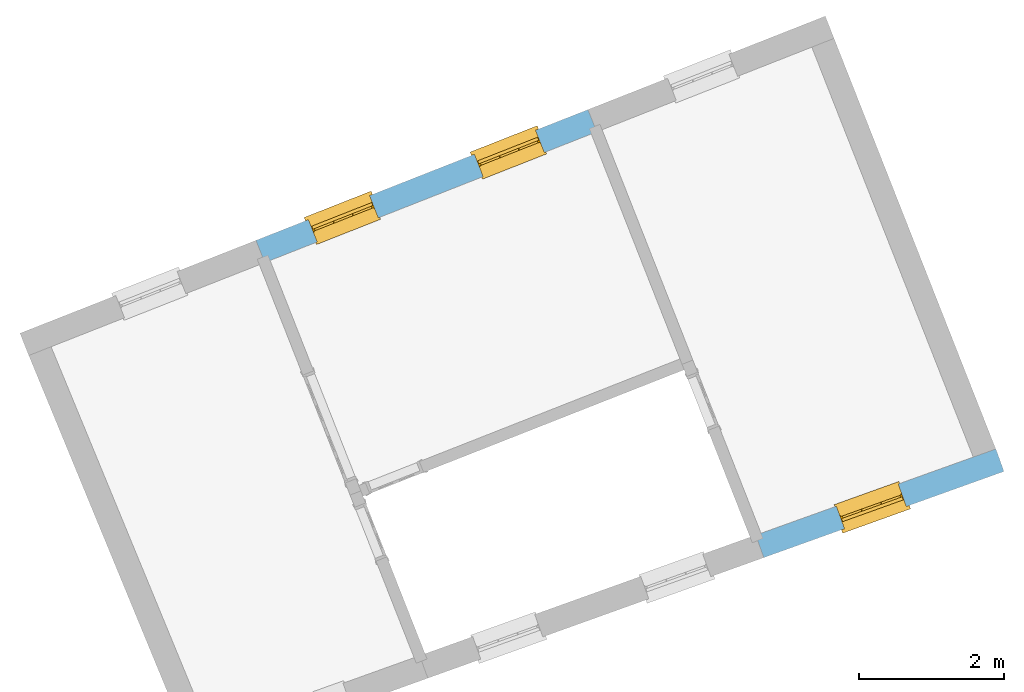
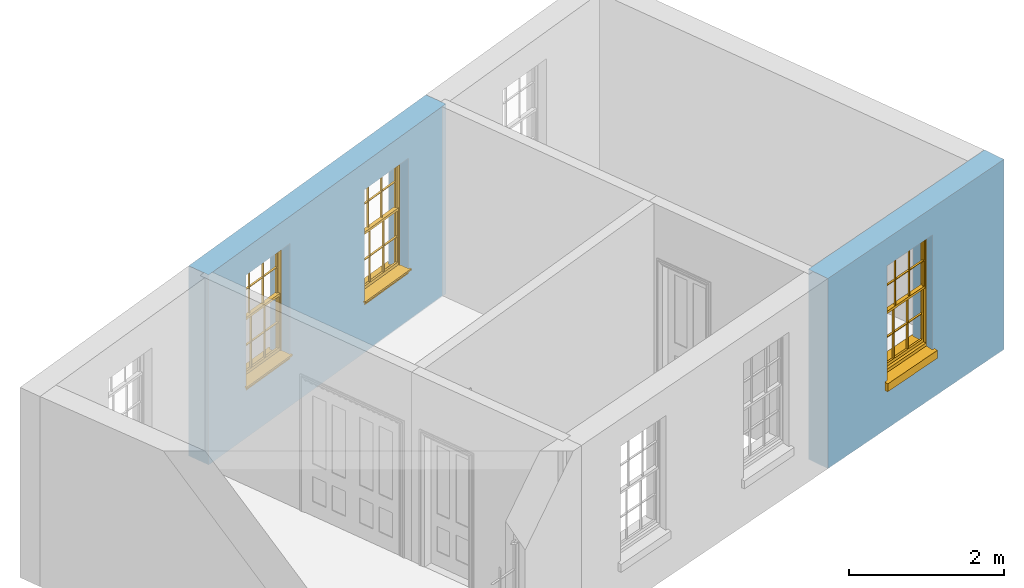
# One storey, part 5 of 6: 3 windows, 3 openings, plus 2 elements that do not belong to this part.
"""IFC2X3 building model written with IfcOpenShell, lengths in metres."""

from ifc_helpers import new_model, si_unit, frame, origin, place, context, subcontext, project, spatial, polyline, outline, extrude, faceted_brep, material, layer, layer_set, layer_usage, element, fill, save


model = new_model("IFC2X3")

# Units and contexts
model_context = context("Model", 3, world=origin())
body_context = subcontext(model_context, "Body", "Model", "MODEL_VIEW")
ifc_project = project(units=[si_unit("PLANEANGLEUNIT", "RADIAN"), si_unit("MASSUNIT", "GRAM", prefix="KILO"), si_unit("FORCEUNIT", "NEWTON", prefix="KILO"), si_unit("LENGTHUNIT", "METRE")], contexts=[model_context])

# Site, building, storey
site_placement = place(None, origin())
site = spatial("IfcSite", under=ifc_project, at=site_placement, CompositionType="ELEMENT")
building_placement = place(None, origin())
building = spatial("IfcBuilding", under=site, at=building_placement, Name="Building plot-4", CompositionType="ELEMENT")
storey_placement = place(None, frame((0.0, 0.0, 6.45)))
storey = spatial("IfcBuildingStorey", under=building, at=storey_placement, Name="Floor 1", CompositionType="ELEMENT", Elevation=6.45)

# Wall, openings, windows
ifc_material = material(Name="Masonry")
ifc_layer = layer(ifc_material, 0.33, ventilated=False)
ifc_layer_set = layer_set([ifc_layer], Name="My Wall")
ifc_layer_usage = layer_usage(ifc_layer_set, "AXIS2", "NEGATIVE", 0.08)
wall_1_placement = place(storey_placement, origin())
wall_1 = element("IfcWallStandardCase", 1, at=wall_1_placement, inside=storey, material=ifc_layer_usage, Name="exterior", context=body_context, shape_type="SweptSolid", body=[
    extrude(outline(polyline([(52.0366920680449, 53.7732303747513), (51.9157706887258, 54.0802776349957), (47.3314871355126, 52.2748946786277), (47.4524085148317, 51.9678474183833), (52.0366920680449, 53.7732303747513)])), origin(), (0.0, 0.0, 1.0), 3.0),
])
opening_1_placement = place(storey_placement, frame((0.0, 0.0, 0.75)))
opening_1 = element("IfcOpeningElement", 2, at=opening_1_placement, cuts=wall_1, Name="Opening", ObjectType="Opening", context=body_context, shape_type="SweptSolid", body=[
    extrude(outline(polyline([(51.1930528410624, 53.7956568279952), (50.3463467597826, 53.4622069638121), (50.4672681391017, 53.1551597035678), (51.3139742203816, 53.4886095677509), (51.1930528410624, 53.7956568279952)])), origin(), (0.0, 0.0, 1.0), 1.82),
])
opening_2_placement = place(storey_placement, frame((0.0, 0.0, 0.75)))
opening_2 = element("IfcOpeningElement", 3, at=opening_2_placement, cuts=wall_1, Name="Opening", ObjectType="Opening", context=body_context, shape_type="SweptSolid", body=[
    extrude(outline(polyline([(48.9009110644558, 52.8929653498112), (48.054204983176, 52.5595154856281), (48.1751263624951, 52.2524682253838), (49.021832443775, 52.5859180895669), (48.9009110644558, 52.8929653498112)])), origin(), (0.0, 0.0, 1.0), 1.82),
])
window_1_placement = place(storey_placement, frame((51.2846599466072, 53.563045267204, 0.75), z_axis=(0.0, 0.0, 1.0), x_axis=(-0.846706081279848, -0.333449864183102, 0.0)))
window_1 = element("IfcWindow", 4, at=window_1_placement, inside=storey, Name="living outside window", OverallHeight=1.82, OverallWidth=0.91, context=body_context, shape_type="Brep", held_by="IfcProductRepresentation", body=[
    faceted_brep([(0.033125, -0.105, 0.975209), (0.01, -0.105, 0.975209), (0.033125, -0.105, 1.376042), (0.876875, -0.105, 0.975209), (0.876875, -0.105, 1.376042), (0.9, -0.105, 0.975209), (0.876875, -0.105, 1.386042), (0.876875, -0.105, 1.786875), (0.9, -0.105, 1.81), (0.033125, -0.105, 1.786875), (0.033125, -0.105, 1.386042), (0.01, -0.105, 1.81), (0.876875, -0.135, 1.376042), (0.876875, -0.135, 0.975209), (0.9, -0.135, 0.937083), (0.033125, -0.135, 1.786875), (0.01, -0.135, 1.81), (0.033125, -0.135, 1.386042), (0.01, -0.135, 0.937083), (0.033125, -0.135, 0.975209), (0.033125, -0.135, 1.376042), (0.876875, -0.135, 1.786875), (0.876875, -0.135, 1.386042), (0.9, -0.135, 1.81), (0.033125, -0.105, 0.937083), (0.01, -0.105, 0.937083), (0.033125, -0.105, 0.53625), (0.876875, -0.105, 0.937083), (0.876875, -0.105, 0.53625), (0.9, -0.105, 0.937083), (0.876875, -0.105, 0.52625), (0.876875, -0.105, 0.125417), (0.9, -0.105, 0.077167), (0.033125, -0.105, 0.125417), (0.033125, -0.105, 0.52625), (0.01, -0.105, 0.077167), (-0.0425, -0.25, 0.01), (-0.0425, -0.3, 0.001667), (0.0, -0.25, 0.01), (0.9525, -0.25, 0.01), (0.91, -0.25, 0.01), (0.9525, -0.3, 0.001667), (-0.02, 0.08, 0.077167), (0.0, 0.08, 0.077167), (-0.02, 0.11, 0.077167), (0.0, -0.06, 0.077167), (0.01, -0.06, 0.077167), (0.91, -0.06, 0.077167), (0.91, 0.08, 0.077167), (0.9, -0.06, 0.077167), (0.93, 0.08, 0.077167), (0.93, 0.11, 0.077167), (0.01, -0.075, 0.975209), (0.9, -0.075, 0.975209), (0.876875, -0.075, 0.125417), (0.876875, -0.075, 0.52625), (0.9, -0.075, 0.077167), (0.876875, -0.075, 0.53625), (0.876875, -0.075, 0.937083), (0.033125, -0.075, 0.125417), (0.01, -0.075, 0.077167), (0.033125, -0.075, 0.52625), (0.033125, -0.075, 0.937083), (0.033125, -0.075, 0.53625), (-0.02, 0.08, 0.052167), (-0.02, 0.11, 0.052167), (0.93, 0.11, 0.052167), (0.93, 0.08, 0.052167), (0.91, 0.08, 0.052167), (0.0, 0.08, 0.052167), (0.91, -0.15, 0.026667), (0.0, -0.15, 0.026667), (-0.0425, -0.3, -0.123333), (0.9525, -0.3, -0.123333), (-0.0425, -0.25, -0.123333), (0.9525, -0.25, -0.123333), (0.01, -0.06, 1.81), (0.9, -0.06, 1.81), (0.0, -0.06, 1.82), (0.91, -0.06, 1.82), (0.01, -0.15, 0.077167), (0.9, -0.15, 0.077167), (0.592292, -0.105, 0.125417), (0.592292, -0.075, 0.125417), (0.317708, -0.075, 0.125417), (0.317708, -0.105, 0.125417), (0.592292, -0.105, 0.53625), (0.317708, -0.105, 0.53625), (0.317708, -0.105, 0.52625), (0.592292, -0.105, 0.52625), (0.592292, -0.075, 0.53625), (0.317708, -0.075, 0.53625), (0.592292, -0.135, 1.386042), (0.592292, -0.105, 1.386042), (0.317708, -0.105, 1.386042), (0.317708, -0.135, 1.386042), (0.317708, -0.135, 1.376042), (0.592292, -0.135, 1.376042), (0.317708, -0.105, 1.376042), (0.592292, -0.105, 1.376042), (0.602292, -0.135, 1.376042), (0.592292, -0.135, 0.975209), (0.602292, -0.135, 0.975209), (0.602292, -0.105, 0.975209), (0.592292, -0.105, 0.975209), (0.602292, -0.105, 1.376042), (0.602292, -0.075, 0.53625), (0.602292, -0.105, 0.53625), (0.317708, -0.075, 0.52625), (0.307708, -0.075, 0.125417), (0.307708, -0.075, 0.52625), (0.602292, -0.075, 0.52625), (0.602292, -0.075, 0.125417), (0.592292, -0.075, 0.52625), (0.307708, -0.075, 0.53625), (0.317708, -0.075, 0.937083), (0.307708, -0.075, 0.937083), (0.602292, -0.075, 0.937083), (0.592292, -0.075, 0.937083), (0.307708, -0.105, 0.52625), (0.307708, -0.105, 0.125417), (0.307708, -0.105, 0.53625), (0.307708, -0.105, 0.937083), (0.592292, -0.105, 0.937083), (0.317708, -0.105, 0.937083), (0.602292, -0.105, 0.937083), (0.602292, -0.105, 0.52625), (0.602292, -0.105, 0.125417), (0.307708, -0.135, 1.386042), (0.307708, -0.135, 1.376042), (0.307708, -0.135, 0.975209), (0.317708, -0.135, 0.975209), (0.317708, -0.135, 1.786875), (0.307708, -0.135, 1.786875), (0.602292, -0.135, 1.786875), (0.592292, -0.135, 1.786875), (0.602292, -0.135, 1.386042), (0.602292, -0.105, 1.386042), (0.307708, -0.105, 1.386042), (0.307708, -0.105, 1.786875), (0.317708, -0.105, 1.786875), (0.592292, -0.105, 1.786875), (0.602292, -0.105, 1.786875), (0.307708, -0.105, 1.376042), (0.317708, -0.105, 0.975209), (0.307708, -0.105, 0.975209), (0.91, -0.15, 1.82), (0.9, -0.15, 1.81), (0.01, -0.15, 1.81), (0.0, -0.15, 1.82), (0.91, -0.25, 0.0), (0.0, -0.25, 0.0), (0.91, 0.08, 0.0), (0.0, 0.08, 0.0)], [[[0, 1, 2]], [[3, 4, 5]], [[6, 7, 8]], [[9, 10, 11]], [[12, 13, 14]], [[15, 16, 17]], [[18, 19, 20]], [[21, 22, 23]], [[24, 25, 26]], [[27, 28, 29]], [[30, 31, 32]], [[33, 34, 35]], [[14, 27, 29]], [[25, 24, 18]], [[36, 37, 38]], [[39, 40, 41]], [[42, 43, 44]], [[45, 46, 43]], [[47, 48, 49]], [[50, 51, 48]], [[1, 0, 52]], [[5, 53, 3]], [[54, 55, 56]], [[57, 58, 53]], [[59, 60, 61]], [[62, 63, 52]], [[48, 43, 46, 49]], [[51, 44, 43, 48]], [[64, 42, 44, 65]], [[65, 44, 51, 66]], [[66, 51, 50, 67]], [[65, 66, 68, 69]], [[60, 56, 49, 46]], [[70, 71, 38, 40]], [[37, 41, 40, 38]], [[37, 72, 73, 41]], [[74, 75, 73, 72]], [[8, 11, 76, 77]], [[76, 78, 79, 77]], [[32, 35, 80, 81]], [[81, 80, 71, 70]], [[82, 83, 84, 85]], [[86, 87, 88, 89]], [[86, 90, 91, 87]], [[92, 93, 94, 95]], [[92, 95, 96, 97]], [[96, 98, 99, 97]], [[100, 97, 101, 102]], [[103, 104, 99, 105]], [[97, 99, 104, 101]], [[102, 103, 105, 100]], [[28, 57, 106, 107]], [[108, 84, 109, 110]], [[111, 112, 83, 113]], [[114, 110, 61, 63]], [[90, 113, 108, 91]], [[115, 91, 114, 116]], [[117, 106, 90, 118]], [[111, 106, 57, 55]], [[119, 110, 109, 120]], [[34, 61, 110, 119]], [[89, 113, 83, 82]], [[88, 108, 113, 89]], [[85, 84, 108, 88]], [[121, 114, 63, 26]], [[122, 116, 114, 121]], [[123, 118, 90, 86]], [[87, 91, 115, 124]], [[107, 106, 117, 125]], [[126, 111, 55, 30]], [[127, 112, 111, 126]], [[126, 30, 28, 107]], [[88, 119, 120, 85]], [[126, 89, 82, 127]], [[125, 123, 86, 107]], [[121, 26, 34, 119]], [[124, 122, 121, 87]], [[128, 17, 20, 129]], [[96, 129, 130, 131]], [[132, 133, 128, 95]], [[134, 135, 92, 136]], [[100, 12, 22, 136]], [[137, 6, 4, 105]], [[94, 138, 139, 140]], [[137, 93, 141, 142]], [[99, 98, 94, 93]], [[143, 2, 10, 138]], [[144, 145, 143, 98]], [[129, 143, 145, 130]], [[20, 2, 143, 129]], [[131, 144, 98, 96]], [[128, 138, 10, 17]], [[133, 139, 138, 128]], [[135, 141, 93, 92]], [[95, 94, 140, 132]], [[22, 6, 137, 136]], [[136, 137, 142, 134]], [[100, 105, 4, 12]], [[107, 86, 89, 126]], [[106, 111, 113, 90]], [[91, 108, 110, 114]], [[87, 121, 119, 88]], [[97, 100, 136, 92]], [[129, 96, 95, 128]], [[98, 143, 138, 94]], [[105, 99, 93, 137]], [[131, 101, 104, 144]], [[124, 115, 118, 123]], [[132, 140, 141, 135]], [[120, 109, 59, 33]], [[15, 9, 139, 133]], [[134, 142, 7, 21]], [[31, 54, 112, 127]], [[36, 74, 72, 37]], [[39, 41, 73, 75]], [[18, 14, 101, 131]], [[23, 16, 132, 135]], [[83, 56, 60, 84]], [[52, 53, 118, 115]], [[53, 52, 144, 104]], [[11, 8, 141, 140]], [[14, 18, 124, 123]], [[2, 1, 11, 10]], [[8, 5, 4, 6]], [[57, 53, 56, 55]], [[60, 52, 63, 61]], [[26, 25, 35, 34]], [[32, 29, 28, 30]], [[14, 23, 22, 12]], [[18, 20, 17, 16]], [[19, 0, 2, 20]], [[17, 10, 9, 15]], [[12, 4, 3, 13]], [[21, 7, 6, 22]], [[27, 58, 57, 28]], [[30, 55, 54, 31]], [[33, 59, 61, 34]], [[26, 63, 62, 24]], [[5, 8, 77, 53]], [[76, 11, 1, 52]], [[46, 45, 78, 76]], [[49, 77, 79, 47]], [[70, 146, 147, 81]], [[71, 80, 148, 149]], [[19, 130, 145, 0]], [[102, 13, 3, 103]], [[116, 122, 24, 62]], [[29, 32, 81, 14]], [[80, 35, 25, 18]], [[60, 46, 76, 52]], [[77, 49, 56, 53]], [[23, 14, 81, 147]], [[16, 148, 80, 18]], [[35, 85, 120]], [[120, 33, 35]], [[127, 82, 32]], [[32, 31, 127]], [[32, 82, 85, 35]], [[102, 101, 14]], [[14, 13, 102]], [[18, 131, 130]], [[130, 19, 18]], [[134, 21, 23]], [[23, 135, 134]], [[16, 15, 133]], [[133, 132, 16]], [[11, 140, 139]], [[139, 9, 11]], [[142, 141, 8]], [[8, 7, 142]], [[23, 147, 148, 16]], [[146, 149, 148, 147]], [[52, 115, 116]], [[116, 62, 52]], [[118, 53, 117]], [[58, 117, 53]], [[27, 125, 117, 58]], [[56, 83, 112]], [[112, 54, 56]], [[109, 84, 60]], [[60, 59, 109]], [[125, 27, 14]], [[14, 123, 125]], [[122, 124, 18]], [[18, 24, 122]], [[145, 144, 52]], [[52, 0, 145]], [[103, 3, 53]], [[53, 104, 103]], [[79, 78, 149, 146]], [[78, 45, 71, 149]], [[146, 70, 47, 79]], [[150, 75, 74, 151]], [[68, 66, 67]], [[48, 68, 67, 50]], [[69, 64, 65]], [[42, 64, 69, 43]], [[69, 68, 152, 153]], [[70, 68, 48, 47]], [[150, 152, 68, 70]], [[43, 69, 71, 45]], [[69, 153, 151, 71]], [[152, 150, 151, 153]], [[38, 151, 74, 36]], [[71, 151, 38]], [[39, 75, 150, 40]], [[40, 150, 70]]]),
])
fill(opening_1, window_1)
window_2_placement = place(storey_placement, frame((48.9925181700006, 52.66035378902, 0.75), z_axis=(0.0, 0.0, 1.0), x_axis=(-0.846706081279848, -0.333449864183102, 0.0)))
window_2 = element("IfcWindow", 5, at=window_2_placement, inside=storey, Name="living outside window", OverallHeight=1.82, OverallWidth=0.91, context=body_context, shape_type="Brep", held_by="IfcProductRepresentation", body=[
    faceted_brep([(0.033125, -0.105, 0.975209), (0.01, -0.105, 0.975209), (0.033125, -0.105, 1.376042), (0.876875, -0.105, 0.975209), (0.876875, -0.105, 1.376042), (0.9, -0.105, 0.975209), (0.876875, -0.105, 1.386042), (0.876875, -0.105, 1.786875), (0.9, -0.105, 1.81), (0.033125, -0.105, 1.786875), (0.033125, -0.105, 1.386042), (0.01, -0.105, 1.81), (0.876875, -0.135, 1.376042), (0.876875, -0.135, 0.975209), (0.9, -0.135, 0.937083), (0.033125, -0.135, 1.786875), (0.01, -0.135, 1.81), (0.033125, -0.135, 1.386042), (0.01, -0.135, 0.937083), (0.033125, -0.135, 0.975209), (0.033125, -0.135, 1.376042), (0.876875, -0.135, 1.786875), (0.876875, -0.135, 1.386042), (0.9, -0.135, 1.81), (0.033125, -0.105, 0.937083), (0.01, -0.105, 0.937083), (0.033125, -0.105, 0.53625), (0.876875, -0.105, 0.937083), (0.876875, -0.105, 0.53625), (0.9, -0.105, 0.937083), (0.876875, -0.105, 0.52625), (0.876875, -0.105, 0.125417), (0.9, -0.105, 0.077167), (0.033125, -0.105, 0.125417), (0.033125, -0.105, 0.52625), (0.01, -0.105, 0.077167), (-0.0425, -0.25, 0.01), (-0.0425, -0.3, 0.001667), (0.0, -0.25, 0.01), (0.9525, -0.25, 0.01), (0.91, -0.25, 0.01), (0.9525, -0.3, 0.001667), (-0.02, 0.08, 0.077167), (0.0, 0.08, 0.077167), (-0.02, 0.11, 0.077167), (0.0, -0.06, 0.077167), (0.01, -0.06, 0.077167), (0.91, -0.06, 0.077167), (0.91, 0.08, 0.077167), (0.9, -0.06, 0.077167), (0.93, 0.08, 0.077167), (0.93, 0.11, 0.077167), (0.01, -0.075, 0.975209), (0.9, -0.075, 0.975209), (0.876875, -0.075, 0.125417), (0.876875, -0.075, 0.52625), (0.9, -0.075, 0.077167), (0.876875, -0.075, 0.53625), (0.876875, -0.075, 0.937083), (0.033125, -0.075, 0.125417), (0.01, -0.075, 0.077167), (0.033125, -0.075, 0.52625), (0.033125, -0.075, 0.937083), (0.033125, -0.075, 0.53625), (-0.02, 0.08, 0.052167), (-0.02, 0.11, 0.052167), (0.93, 0.11, 0.052167), (0.93, 0.08, 0.052167), (0.91, 0.08, 0.052167), (0.0, 0.08, 0.052167), (0.91, -0.15, 0.026667), (0.0, -0.15, 0.026667), (-0.0425, -0.3, -0.123333), (0.9525, -0.3, -0.123333), (-0.0425, -0.25, -0.123333), (0.9525, -0.25, -0.123333), (0.01, -0.06, 1.81), (0.9, -0.06, 1.81), (0.0, -0.06, 1.82), (0.91, -0.06, 1.82), (0.01, -0.15, 0.077167), (0.9, -0.15, 0.077167), (0.592292, -0.105, 0.125417), (0.592292, -0.075, 0.125417), (0.317708, -0.075, 0.125417), (0.317708, -0.105, 0.125417), (0.592292, -0.105, 0.53625), (0.317708, -0.105, 0.53625), (0.317708, -0.105, 0.52625), (0.592292, -0.105, 0.52625), (0.592292, -0.075, 0.53625), (0.317708, -0.075, 0.53625), (0.592292, -0.135, 1.386042), (0.592292, -0.105, 1.386042), (0.317708, -0.105, 1.386042), (0.317708, -0.135, 1.386042), (0.317708, -0.135, 1.376042), (0.592292, -0.135, 1.376042), (0.317708, -0.105, 1.376042), (0.592292, -0.105, 1.376042), (0.602292, -0.135, 1.376042), (0.592292, -0.135, 0.975209), (0.602292, -0.135, 0.975209), (0.602292, -0.105, 0.975209), (0.592292, -0.105, 0.975209), (0.602292, -0.105, 1.376042), (0.602292, -0.075, 0.53625), (0.602292, -0.105, 0.53625), (0.317708, -0.075, 0.52625), (0.307708, -0.075, 0.125417), (0.307708, -0.075, 0.52625), (0.602292, -0.075, 0.52625), (0.602292, -0.075, 0.125417), (0.592292, -0.075, 0.52625), (0.307708, -0.075, 0.53625), (0.317708, -0.075, 0.937083), (0.307708, -0.075, 0.937083), (0.602292, -0.075, 0.937083), (0.592292, -0.075, 0.937083), (0.307708, -0.105, 0.52625), (0.307708, -0.105, 0.125417), (0.307708, -0.105, 0.53625), (0.307708, -0.105, 0.937083), (0.592292, -0.105, 0.937083), (0.317708, -0.105, 0.937083), (0.602292, -0.105, 0.937083), (0.602292, -0.105, 0.52625), (0.602292, -0.105, 0.125417), (0.307708, -0.135, 1.386042), (0.307708, -0.135, 1.376042), (0.307708, -0.135, 0.975209), (0.317708, -0.135, 0.975209), (0.317708, -0.135, 1.786875), (0.307708, -0.135, 1.786875), (0.602292, -0.135, 1.786875), (0.592292, -0.135, 1.786875), (0.602292, -0.135, 1.386042), (0.602292, -0.105, 1.386042), (0.307708, -0.105, 1.386042), (0.307708, -0.105, 1.786875), (0.317708, -0.105, 1.786875), (0.592292, -0.105, 1.786875), (0.602292, -0.105, 1.786875), (0.307708, -0.105, 1.376042), (0.317708, -0.105, 0.975209), (0.307708, -0.105, 0.975209), (0.91, -0.15, 1.82), (0.9, -0.15, 1.81), (0.01, -0.15, 1.81), (0.0, -0.15, 1.82), (0.91, -0.25, 0.0), (0.0, -0.25, 0.0), (0.91, 0.08, 0.0), (0.0, 0.08, 0.0)], [[[0, 1, 2]], [[3, 4, 5]], [[6, 7, 8]], [[9, 10, 11]], [[12, 13, 14]], [[15, 16, 17]], [[18, 19, 20]], [[21, 22, 23]], [[24, 25, 26]], [[27, 28, 29]], [[30, 31, 32]], [[33, 34, 35]], [[14, 27, 29]], [[25, 24, 18]], [[36, 37, 38]], [[39, 40, 41]], [[42, 43, 44]], [[45, 46, 43]], [[47, 48, 49]], [[50, 51, 48]], [[1, 0, 52]], [[5, 53, 3]], [[54, 55, 56]], [[57, 58, 53]], [[59, 60, 61]], [[62, 63, 52]], [[48, 43, 46, 49]], [[51, 44, 43, 48]], [[64, 42, 44, 65]], [[65, 44, 51, 66]], [[66, 51, 50, 67]], [[65, 66, 68, 69]], [[60, 56, 49, 46]], [[70, 71, 38, 40]], [[37, 41, 40, 38]], [[37, 72, 73, 41]], [[74, 75, 73, 72]], [[8, 11, 76, 77]], [[76, 78, 79, 77]], [[32, 35, 80, 81]], [[81, 80, 71, 70]], [[82, 83, 84, 85]], [[86, 87, 88, 89]], [[86, 90, 91, 87]], [[92, 93, 94, 95]], [[92, 95, 96, 97]], [[96, 98, 99, 97]], [[100, 97, 101, 102]], [[103, 104, 99, 105]], [[97, 99, 104, 101]], [[102, 103, 105, 100]], [[28, 57, 106, 107]], [[108, 84, 109, 110]], [[111, 112, 83, 113]], [[114, 110, 61, 63]], [[90, 113, 108, 91]], [[115, 91, 114, 116]], [[117, 106, 90, 118]], [[111, 106, 57, 55]], [[119, 110, 109, 120]], [[34, 61, 110, 119]], [[89, 113, 83, 82]], [[88, 108, 113, 89]], [[85, 84, 108, 88]], [[121, 114, 63, 26]], [[122, 116, 114, 121]], [[123, 118, 90, 86]], [[87, 91, 115, 124]], [[107, 106, 117, 125]], [[126, 111, 55, 30]], [[127, 112, 111, 126]], [[126, 30, 28, 107]], [[88, 119, 120, 85]], [[126, 89, 82, 127]], [[125, 123, 86, 107]], [[121, 26, 34, 119]], [[124, 122, 121, 87]], [[128, 17, 20, 129]], [[96, 129, 130, 131]], [[132, 133, 128, 95]], [[134, 135, 92, 136]], [[100, 12, 22, 136]], [[137, 6, 4, 105]], [[94, 138, 139, 140]], [[137, 93, 141, 142]], [[99, 98, 94, 93]], [[143, 2, 10, 138]], [[144, 145, 143, 98]], [[129, 143, 145, 130]], [[20, 2, 143, 129]], [[131, 144, 98, 96]], [[128, 138, 10, 17]], [[133, 139, 138, 128]], [[135, 141, 93, 92]], [[95, 94, 140, 132]], [[22, 6, 137, 136]], [[136, 137, 142, 134]], [[100, 105, 4, 12]], [[107, 86, 89, 126]], [[106, 111, 113, 90]], [[91, 108, 110, 114]], [[87, 121, 119, 88]], [[97, 100, 136, 92]], [[129, 96, 95, 128]], [[98, 143, 138, 94]], [[105, 99, 93, 137]], [[131, 101, 104, 144]], [[124, 115, 118, 123]], [[132, 140, 141, 135]], [[120, 109, 59, 33]], [[15, 9, 139, 133]], [[134, 142, 7, 21]], [[31, 54, 112, 127]], [[36, 74, 72, 37]], [[39, 41, 73, 75]], [[18, 14, 101, 131]], [[23, 16, 132, 135]], [[83, 56, 60, 84]], [[52, 53, 118, 115]], [[53, 52, 144, 104]], [[11, 8, 141, 140]], [[14, 18, 124, 123]], [[2, 1, 11, 10]], [[8, 5, 4, 6]], [[57, 53, 56, 55]], [[60, 52, 63, 61]], [[26, 25, 35, 34]], [[32, 29, 28, 30]], [[14, 23, 22, 12]], [[18, 20, 17, 16]], [[19, 0, 2, 20]], [[17, 10, 9, 15]], [[12, 4, 3, 13]], [[21, 7, 6, 22]], [[27, 58, 57, 28]], [[30, 55, 54, 31]], [[33, 59, 61, 34]], [[26, 63, 62, 24]], [[5, 8, 77, 53]], [[76, 11, 1, 52]], [[46, 45, 78, 76]], [[49, 77, 79, 47]], [[70, 146, 147, 81]], [[71, 80, 148, 149]], [[19, 130, 145, 0]], [[102, 13, 3, 103]], [[116, 122, 24, 62]], [[29, 32, 81, 14]], [[80, 35, 25, 18]], [[60, 46, 76, 52]], [[77, 49, 56, 53]], [[23, 14, 81, 147]], [[16, 148, 80, 18]], [[35, 85, 120]], [[120, 33, 35]], [[127, 82, 32]], [[32, 31, 127]], [[32, 82, 85, 35]], [[102, 101, 14]], [[14, 13, 102]], [[18, 131, 130]], [[130, 19, 18]], [[134, 21, 23]], [[23, 135, 134]], [[16, 15, 133]], [[133, 132, 16]], [[11, 140, 139]], [[139, 9, 11]], [[142, 141, 8]], [[8, 7, 142]], [[23, 147, 148, 16]], [[146, 149, 148, 147]], [[52, 115, 116]], [[116, 62, 52]], [[118, 53, 117]], [[58, 117, 53]], [[27, 125, 117, 58]], [[56, 83, 112]], [[112, 54, 56]], [[109, 84, 60]], [[60, 59, 109]], [[125, 27, 14]], [[14, 123, 125]], [[122, 124, 18]], [[18, 24, 122]], [[145, 144, 52]], [[52, 0, 145]], [[103, 3, 53]], [[53, 104, 103]], [[79, 78, 149, 146]], [[78, 45, 71, 149]], [[146, 70, 47, 79]], [[150, 75, 74, 151]], [[68, 66, 67]], [[48, 68, 67, 50]], [[69, 64, 65]], [[42, 64, 69, 43]], [[69, 68, 152, 153]], [[70, 68, 48, 47]], [[150, 152, 68, 70]], [[43, 69, 71, 45]], [[69, 153, 151, 71]], [[152, 150, 151, 153]], [[38, 151, 74, 36]], [[71, 151, 38]], [[39, 75, 150, 40]], [[40, 150, 70]]]),
])
fill(opening_2, window_2)

# Wall, opening, window
wall_2_placement = place(storey_placement, origin())
wall_2 = element("IfcWallStandardCase", 6, at=wall_2_placement, inside=storey, material=ifc_layer_usage, Name="exterior", context=body_context, shape_type="SweptSolid", body=[
    extrude(outline(polyline([(54.2325115600524, 48.2042385175559), (54.3439530966588, 47.8936249571326), (57.6606145588137, 49.0835725216947), (57.5491730222074, 49.394186082118), (54.2325115600524, 48.2042385175559)])), origin(), (0.0, 0.0, 1.0), 3.0),
])
opening_3_placement = place(storey_placement, frame((0.0, 0.0, 0.75)))
opening_3 = element("IfcOpeningElement", 7, at=opening_3_placement, cuts=wall_2, Name="Opening", ObjectType="Opening", context=body_context, shape_type="SweptSolid", body=[
    extrude(outline(polyline([(55.456356963962, 48.2927317962874), (56.3128973881595, 48.60004027602), (56.2014558515532, 48.9106538364433), (55.3449154273557, 48.6033453567106), (55.456356963962, 48.2927317962874)])), origin(), (0.0, 0.0, 1.0), 1.82),
])
window_3_placement = place(storey_placement, frame((55.3719315574421, 48.5280450996383, 0.75), z_axis=(0.0, 0.0, 1.0), x_axis=(0.856540424197483, 0.307308479732662, 0.0)))
window_3 = element("IfcWindow", 8, at=window_3_placement, inside=storey, Name="bedroom outside window", OverallHeight=1.82, OverallWidth=0.91, context=body_context, shape_type="Brep", held_by="IfcProductRepresentation", body=[
    faceted_brep([(0.033125, -0.105, 0.975209), (0.01, -0.105, 0.975209), (0.033125, -0.105, 1.376042), (0.876875, -0.105, 0.975209), (0.876875, -0.105, 1.376042), (0.9, -0.105, 0.975209), (0.876875, -0.105, 1.386042), (0.876875, -0.105, 1.786875), (0.9, -0.105, 1.81), (0.033125, -0.105, 1.786875), (0.033125, -0.105, 1.386042), (0.01, -0.105, 1.81), (0.876875, -0.135, 1.376042), (0.876875, -0.135, 0.975209), (0.9, -0.135, 0.937083), (0.033125, -0.135, 1.786875), (0.01, -0.135, 1.81), (0.033125, -0.135, 1.386042), (0.01, -0.135, 0.937083), (0.033125, -0.135, 0.975209), (0.033125, -0.135, 1.376042), (0.876875, -0.135, 1.786875), (0.876875, -0.135, 1.386042), (0.9, -0.135, 1.81), (0.033125, -0.105, 0.937083), (0.01, -0.105, 0.937083), (0.033125, -0.105, 0.53625), (0.876875, -0.105, 0.937083), (0.876875, -0.105, 0.53625), (0.9, -0.105, 0.937083), (0.876875, -0.105, 0.52625), (0.876875, -0.105, 0.125417), (0.9, -0.105, 0.077167), (0.033125, -0.105, 0.125417), (0.033125, -0.105, 0.52625), (0.01, -0.105, 0.077167), (-0.0425, -0.25, 0.01), (-0.0425, -0.3, 0.001667), (0.0, -0.25, 0.01), (0.9525, -0.25, 0.01), (0.91, -0.25, 0.01), (0.9525, -0.3, 0.001667), (-0.02, 0.08, 0.077167), (0.0, 0.08, 0.077167), (-0.02, 0.11, 0.077167), (0.0, -0.06, 0.077167), (0.01, -0.06, 0.077167), (0.91, -0.06, 0.077167), (0.91, 0.08, 0.077167), (0.9, -0.06, 0.077167), (0.93, 0.08, 0.077167), (0.93, 0.11, 0.077167), (0.01, -0.075, 0.975209), (0.9, -0.075, 0.975209), (0.876875, -0.075, 0.125417), (0.876875, -0.075, 0.52625), (0.9, -0.075, 0.077167), (0.876875, -0.075, 0.53625), (0.876875, -0.075, 0.937083), (0.033125, -0.075, 0.125417), (0.01, -0.075, 0.077167), (0.033125, -0.075, 0.52625), (0.033125, -0.075, 0.937083), (0.033125, -0.075, 0.53625), (-0.02, 0.08, 0.052167), (-0.02, 0.11, 0.052167), (0.93, 0.11, 0.052167), (0.93, 0.08, 0.052167), (0.91, 0.08, 0.052167), (0.0, 0.08, 0.052167), (0.91, -0.15, 0.026667), (0.0, -0.15, 0.026667), (-0.0425, -0.3, -0.123333), (0.9525, -0.3, -0.123333), (-0.0425, -0.25, -0.123333), (0.9525, -0.25, -0.123333), (0.01, -0.06, 1.81), (0.9, -0.06, 1.81), (0.0, -0.06, 1.82), (0.91, -0.06, 1.82), (0.01, -0.15, 0.077167), (0.9, -0.15, 0.077167), (0.592292, -0.105, 0.125417), (0.592292, -0.075, 0.125417), (0.317708, -0.075, 0.125417), (0.317708, -0.105, 0.125417), (0.592292, -0.105, 0.53625), (0.317708, -0.105, 0.53625), (0.317708, -0.105, 0.52625), (0.592292, -0.105, 0.52625), (0.592292, -0.075, 0.53625), (0.317708, -0.075, 0.53625), (0.592292, -0.135, 1.386042), (0.592292, -0.105, 1.386042), (0.317708, -0.105, 1.386042), (0.317708, -0.135, 1.386042), (0.317708, -0.135, 1.376042), (0.592292, -0.135, 1.376042), (0.317708, -0.105, 1.376042), (0.592292, -0.105, 1.376042), (0.602292, -0.135, 1.376042), (0.592292, -0.135, 0.975209), (0.602292, -0.135, 0.975209), (0.602292, -0.105, 0.975209), (0.592292, -0.105, 0.975209), (0.602292, -0.105, 1.376042), (0.602292, -0.075, 0.53625), (0.602292, -0.105, 0.53625), (0.317708, -0.075, 0.52625), (0.307708, -0.075, 0.125417), (0.307708, -0.075, 0.52625), (0.602292, -0.075, 0.52625), (0.602292, -0.075, 0.125417), (0.592292, -0.075, 0.52625), (0.307708, -0.075, 0.53625), (0.317708, -0.075, 0.937083), (0.307708, -0.075, 0.937083), (0.602292, -0.075, 0.937083), (0.592292, -0.075, 0.937083), (0.307708, -0.105, 0.52625), (0.307708, -0.105, 0.125417), (0.307708, -0.105, 0.53625), (0.307708, -0.105, 0.937083), (0.592292, -0.105, 0.937083), (0.317708, -0.105, 0.937083), (0.602292, -0.105, 0.937083), (0.602292, -0.105, 0.52625), (0.602292, -0.105, 0.125417), (0.307708, -0.135, 1.386042), (0.307708, -0.135, 1.376042), (0.307708, -0.135, 0.975209), (0.317708, -0.135, 0.975209), (0.317708, -0.135, 1.786875), (0.307708, -0.135, 1.786875), (0.602292, -0.135, 1.786875), (0.592292, -0.135, 1.786875), (0.602292, -0.135, 1.386042), (0.602292, -0.105, 1.386042), (0.307708, -0.105, 1.386042), (0.307708, -0.105, 1.786875), (0.317708, -0.105, 1.786875), (0.592292, -0.105, 1.786875), (0.602292, -0.105, 1.786875), (0.307708, -0.105, 1.376042), (0.317708, -0.105, 0.975209), (0.307708, -0.105, 0.975209), (0.91, -0.15, 1.82), (0.9, -0.15, 1.81), (0.01, -0.15, 1.81), (0.0, -0.15, 1.82), (0.91, -0.25, 0.0), (0.0, -0.25, 0.0), (0.91, 0.08, 0.0), (0.0, 0.08, 0.0)], [[[0, 1, 2]], [[3, 4, 5]], [[6, 7, 8]], [[9, 10, 11]], [[12, 13, 14]], [[15, 16, 17]], [[18, 19, 20]], [[21, 22, 23]], [[24, 25, 26]], [[27, 28, 29]], [[30, 31, 32]], [[33, 34, 35]], [[14, 27, 29]], [[25, 24, 18]], [[36, 37, 38]], [[39, 40, 41]], [[42, 43, 44]], [[45, 46, 43]], [[47, 48, 49]], [[50, 51, 48]], [[1, 0, 52]], [[5, 53, 3]], [[54, 55, 56]], [[57, 58, 53]], [[59, 60, 61]], [[62, 63, 52]], [[48, 43, 46, 49]], [[51, 44, 43, 48]], [[64, 42, 44, 65]], [[65, 44, 51, 66]], [[66, 51, 50, 67]], [[65, 66, 68, 69]], [[60, 56, 49, 46]], [[70, 71, 38, 40]], [[37, 41, 40, 38]], [[37, 72, 73, 41]], [[74, 75, 73, 72]], [[8, 11, 76, 77]], [[76, 78, 79, 77]], [[32, 35, 80, 81]], [[81, 80, 71, 70]], [[82, 83, 84, 85]], [[86, 87, 88, 89]], [[86, 90, 91, 87]], [[92, 93, 94, 95]], [[92, 95, 96, 97]], [[96, 98, 99, 97]], [[100, 97, 101, 102]], [[103, 104, 99, 105]], [[97, 99, 104, 101]], [[102, 103, 105, 100]], [[28, 57, 106, 107]], [[108, 84, 109, 110]], [[111, 112, 83, 113]], [[114, 110, 61, 63]], [[90, 113, 108, 91]], [[115, 91, 114, 116]], [[117, 106, 90, 118]], [[111, 106, 57, 55]], [[119, 110, 109, 120]], [[34, 61, 110, 119]], [[89, 113, 83, 82]], [[88, 108, 113, 89]], [[85, 84, 108, 88]], [[121, 114, 63, 26]], [[122, 116, 114, 121]], [[123, 118, 90, 86]], [[87, 91, 115, 124]], [[107, 106, 117, 125]], [[126, 111, 55, 30]], [[127, 112, 111, 126]], [[126, 30, 28, 107]], [[88, 119, 120, 85]], [[126, 89, 82, 127]], [[125, 123, 86, 107]], [[121, 26, 34, 119]], [[124, 122, 121, 87]], [[128, 17, 20, 129]], [[96, 129, 130, 131]], [[132, 133, 128, 95]], [[134, 135, 92, 136]], [[100, 12, 22, 136]], [[137, 6, 4, 105]], [[94, 138, 139, 140]], [[137, 93, 141, 142]], [[99, 98, 94, 93]], [[143, 2, 10, 138]], [[144, 145, 143, 98]], [[129, 143, 145, 130]], [[20, 2, 143, 129]], [[131, 144, 98, 96]], [[128, 138, 10, 17]], [[133, 139, 138, 128]], [[135, 141, 93, 92]], [[95, 94, 140, 132]], [[22, 6, 137, 136]], [[136, 137, 142, 134]], [[100, 105, 4, 12]], [[107, 86, 89, 126]], [[106, 111, 113, 90]], [[91, 108, 110, 114]], [[87, 121, 119, 88]], [[97, 100, 136, 92]], [[129, 96, 95, 128]], [[98, 143, 138, 94]], [[105, 99, 93, 137]], [[131, 101, 104, 144]], [[124, 115, 118, 123]], [[132, 140, 141, 135]], [[120, 109, 59, 33]], [[15, 9, 139, 133]], [[134, 142, 7, 21]], [[31, 54, 112, 127]], [[36, 74, 72, 37]], [[39, 41, 73, 75]], [[18, 14, 101, 131]], [[23, 16, 132, 135]], [[83, 56, 60, 84]], [[52, 53, 118, 115]], [[53, 52, 144, 104]], [[11, 8, 141, 140]], [[14, 18, 124, 123]], [[2, 1, 11, 10]], [[8, 5, 4, 6]], [[57, 53, 56, 55]], [[60, 52, 63, 61]], [[26, 25, 35, 34]], [[32, 29, 28, 30]], [[14, 23, 22, 12]], [[18, 20, 17, 16]], [[19, 0, 2, 20]], [[17, 10, 9, 15]], [[12, 4, 3, 13]], [[21, 7, 6, 22]], [[27, 58, 57, 28]], [[30, 55, 54, 31]], [[33, 59, 61, 34]], [[26, 63, 62, 24]], [[5, 8, 77, 53]], [[76, 11, 1, 52]], [[46, 45, 78, 76]], [[49, 77, 79, 47]], [[70, 146, 147, 81]], [[71, 80, 148, 149]], [[19, 130, 145, 0]], [[102, 13, 3, 103]], [[116, 122, 24, 62]], [[29, 32, 81, 14]], [[80, 35, 25, 18]], [[60, 46, 76, 52]], [[77, 49, 56, 53]], [[23, 14, 81, 147]], [[16, 148, 80, 18]], [[35, 85, 120]], [[120, 33, 35]], [[127, 82, 32]], [[32, 31, 127]], [[32, 82, 85, 35]], [[102, 101, 14]], [[14, 13, 102]], [[18, 131, 130]], [[130, 19, 18]], [[134, 21, 23]], [[23, 135, 134]], [[16, 15, 133]], [[133, 132, 16]], [[11, 140, 139]], [[139, 9, 11]], [[142, 141, 8]], [[8, 7, 142]], [[23, 147, 148, 16]], [[146, 149, 148, 147]], [[52, 115, 116]], [[116, 62, 52]], [[118, 53, 117]], [[58, 117, 53]], [[27, 125, 117, 58]], [[56, 83, 112]], [[112, 54, 56]], [[109, 84, 60]], [[60, 59, 109]], [[125, 27, 14]], [[14, 123, 125]], [[122, 124, 18]], [[18, 24, 122]], [[145, 144, 52]], [[52, 0, 145]], [[103, 3, 53]], [[53, 104, 103]], [[79, 78, 149, 146]], [[78, 45, 71, 149]], [[146, 70, 47, 79]], [[150, 75, 74, 151]], [[68, 66, 67]], [[48, 68, 67, 50]], [[69, 64, 65]], [[42, 64, 69, 43]], [[69, 68, 152, 153]], [[70, 68, 48, 47]], [[150, 152, 68, 70]], [[43, 69, 71, 45]], [[69, 153, 151, 71]], [[152, 150, 151, 153]], [[38, 151, 74, 36]], [[71, 151, 38]], [[39, 75, 150, 40]], [[40, 150, 70]]]),
])
fill(opening_3, window_3)

save(model, "model.ifc")
